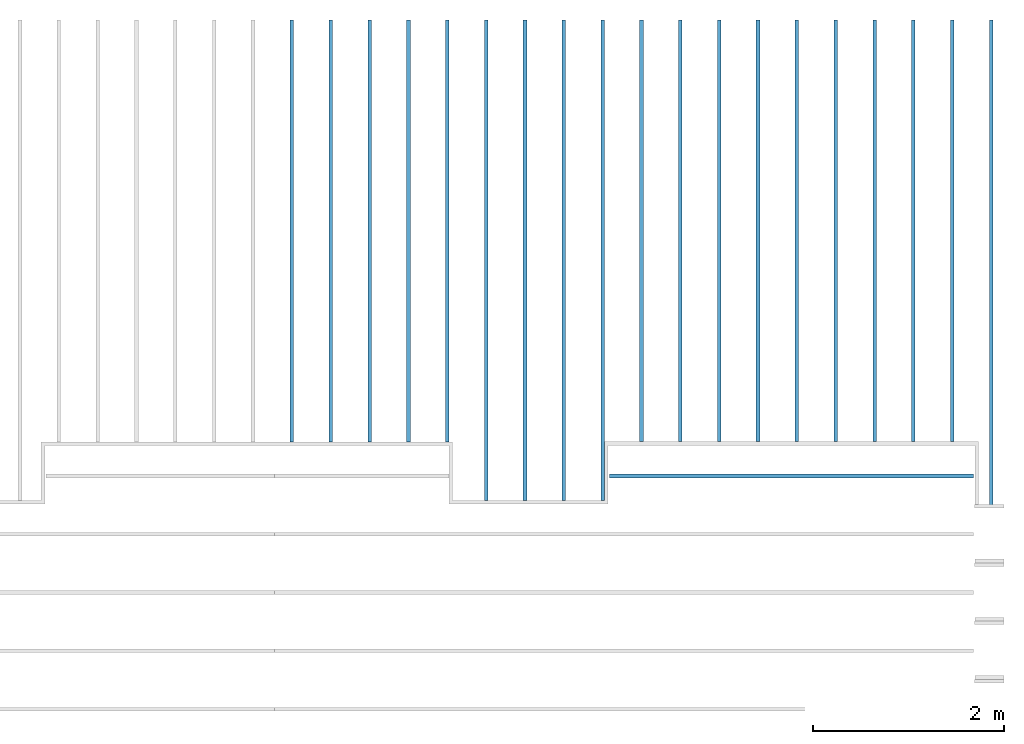
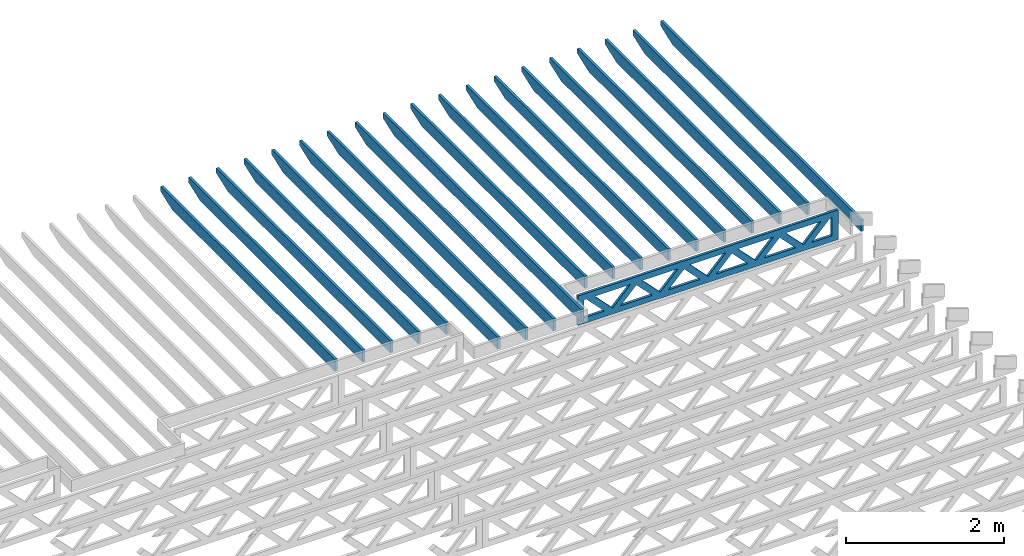
# One storey, part 13 of 18: 20 beams, 2 elements without a shape of their own.
"""IFC4 building model written with IfcOpenShell, lengths in feet."""

from ifc_helpers import new_model, entity, si_unit, converted_unit, derived_unit, direction, frame, frame_2d, origin, origin_2d_with_axis, place, context, subcontext, project, spatial, rectangle, extrude, clip, halfspace, source, transform, mapped, material, material_profile, profile_set, profile_usage, type_object, type_shapes, element, aggregate, save


model = new_model("IFC4")

# Units and contexts
model_context_1 = context("Model", 3, precision=0.0001, world=origin(), true_north=direction((6.12303176911189e-17, 1.0)))
model_context_2 = context("Model", 3, precision=0.0001, world=origin(), true_north=direction((6.12303176911189e-17, 1.0)))
body_context = subcontext(model_context_2, "Body", "Model", "MODEL_VIEW")
ifc_project = project(units=[converted_unit("LENGTHUNIT", "FOOT", entity("IfcRatioMeasure", 0.3048), si_unit("LENGTHUNIT", "METRE"), dimensions=[1, 0, 0, 0, 0, 0, 0]), converted_unit("AREAUNIT", "SQUARE FOOT", entity("IfcRatioMeasure", 0.09290304), si_unit("AREAUNIT", "SQUARE_METRE"), dimensions=[2, 0, 0, 0, 0, 0, 0]), converted_unit("VOLUMEUNIT", "CUBIC FOOT", entity("IfcRatioMeasure", 0.028316846592), si_unit("VOLUMEUNIT", "CUBIC_METRE"), dimensions=[3, 0, 0, 0, 0, 0, 0]), converted_unit("PLANEANGLEUNIT", "DEGREE", entity("IfcRatioMeasure", 0.0174532925199433), si_unit("PLANEANGLEUNIT", "RADIAN"), dimensions=[0, 0, 0, 0, 0, 0, 0]), si_unit("MASSUNIT", "GRAM", prefix="KILO"), derived_unit("MASSDENSITYUNIT", [(si_unit("MASSUNIT", "GRAM", prefix="KILO"), 1), (si_unit("LENGTHUNIT", "METRE"), -3)]), derived_unit("MOMENTOFINERTIAUNIT", [(si_unit("LENGTHUNIT", "METRE"), 4)]), si_unit("TIMEUNIT", "SECOND"), si_unit("FREQUENCYUNIT", "HERTZ"), si_unit("THERMODYNAMICTEMPERATUREUNIT", "DEGREE_CELSIUS"), derived_unit("THERMALTRANSMITTANCEUNIT", [(si_unit("MASSUNIT", "GRAM", prefix="KILO"), 1), (si_unit("THERMODYNAMICTEMPERATUREUNIT", "KELVIN"), -1), (si_unit("TIMEUNIT", "SECOND"), -3)]), derived_unit("VOLUMETRICFLOWRATEUNIT", [(si_unit("LENGTHUNIT", "METRE"), 3), (si_unit("TIMEUNIT", "SECOND"), -1)]), si_unit("ELECTRICCURRENTUNIT", "AMPERE"), si_unit("ELECTRICVOLTAGEUNIT", "VOLT"), si_unit("POWERUNIT", "WATT"), si_unit("FORCEUNIT", "NEWTON"), si_unit("ILLUMINANCEUNIT", "LUX"), si_unit("LUMINOUSFLUXUNIT", "LUMEN"), si_unit("LUMINOUSINTENSITYUNIT", "CANDELA"), derived_unit("USERDEFINED", [(si_unit("MASSUNIT", "GRAM", prefix="KILO"), -1), (si_unit("LENGTHUNIT", "METRE"), -2), (si_unit("TIMEUNIT", "SECOND"), 3), (si_unit("LUMINOUSFLUXUNIT", "LUMEN"), 1)]), derived_unit("LINEARVELOCITYUNIT", [(si_unit("LENGTHUNIT", "METRE"), 1), (si_unit("TIMEUNIT", "SECOND"), -1)]), si_unit("PRESSUREUNIT", "PASCAL"), derived_unit("USERDEFINED", [(si_unit("LENGTHUNIT", "METRE"), -2), (si_unit("MASSUNIT", "GRAM", prefix="KILO"), 1), (si_unit("TIMEUNIT", "SECOND"), -2)]), derived_unit("LINEARFORCEUNIT", [(si_unit("MASSUNIT", "GRAM", prefix="KILO"), 1), (si_unit("LENGTHUNIT", "METRE"), 1), (si_unit("TIMEUNIT", "SECOND"), -2), (si_unit("LENGTHUNIT", "METRE"), -1)]), derived_unit("PLANARFORCEUNIT", [(si_unit("MASSUNIT", "GRAM", prefix="KILO"), 1), (si_unit("LENGTHUNIT", "METRE"), 1), (si_unit("TIMEUNIT", "SECOND"), -2), (si_unit("LENGTHUNIT", "METRE"), -2)])], contexts=[model_context_1])

# Site, building, storey
site_placement = place(None, origin())
site = spatial("IfcSite", under=ifc_project, at=site_placement, CompositionType="ELEMENT")
building_placement = place(site_placement, origin())
building = spatial("IfcBuilding", under=site, at=building_placement, CompositionType="ELEMENT")
storey_placement = place(building_placement, frame((0.0, 0.0, 30.4375000000082)))
storey = spatial("IfcBuildingStorey", under=building, at=storey_placement, Name="ROOF", CompositionType="ELEMENT", Elevation=30.4375000000082)

# Assembly, beams
assembly_1_placement = place(storey_placement, origin())
assembly_1 = element("IfcElementAssembly", 1, at=assembly_1_placement, inside=storey, Name="Structural Beam System:Structural Framing System", ObjectType="Structural Beam System:Structural Framing System", AssemblyPlace="NOTDEFINED", PredefinedType="BEAM_GRID")
ifc_material_1 = material(Name="2X ROOF JOISTS - EXT. STAIN-1 - SEE LIFE SAFETY", Category="Materials")
ifc_material_profile_1 = material_profile(ifc_material_1, rectangle(XDim=0.604166666666667, YDim=0.125000000000011, at=frame_2d((0.0, 0.0), x_axis=(0.0, 1.0))))
ifc_profile_set_1 = profile_set([ifc_material_profile_1])
ifc_profile_usage_1 = profile_usage(ifc_profile_set_1, cardinal=8)
beam_type_1 = type_object("IfcBeamType", PredefinedType="BEAM", material=ifc_profile_set_1)
shared_shape_1 = source(origin(), body_context, "Body", "Clipping", [
    clip(extrude(rectangle(XDim=0.604166666666667, YDim=0.125000000000011, at=frame_2d((0.0, 0.0), x_axis=(0.0, 1.0))), frame((-8.24296473987818, 0.0, 0.0), z_axis=(1.0, 0.0, 0.0), x_axis=(0.0, 1.0, 0.0)), (0.0, 0.0, 1.0), 16.4859294797564), halfspace(frame((-7.26989982048795, -0.0625000000000026, -0.30208333333334), z_axis=(-0.34202014332567, 0.0, -0.939692620785908), x_axis=(0.0, 1.0, 0.0)), False)),
])
type_shapes(beam_type_1, [shared_shape_1])
beam_1_placement = place(assembly_1_placement, frame((-154.467327152128, 965.271566289195, 1.07291666665829), z_axis=(0.0, 0.0, 1.0), x_axis=(0.0, -1.0, 0.0)))
beam_1 = element("IfcBeam", 2, at=beam_1_placement, type_object=beam_type_1, material=ifc_profile_usage_1, PredefinedType="BEAM", context=body_context, shape_type="MappedRepresentation", body=[
    mapped(shared_shape_1, transform((0.0, 0.0, 0.0), scale=1.0)),
])
ifc_profile_usage_2 = profile_usage(ifc_profile_set_1, cardinal=8)
beam_2_placement = place(assembly_1_placement, frame((-153.133993818795, 965.271566289195, 1.07291666665829), z_axis=(0.0, 0.0, 1.0), x_axis=(0.0, -1.0, 0.0)))
beam_2 = element("IfcBeam", 3, at=beam_2_placement, type_object=beam_type_1, material=ifc_profile_usage_2, PredefinedType="BEAM", context=body_context, shape_type="MappedRepresentation", body=[
    mapped(shared_shape_1, transform((0.0, 0.0, 0.0), scale=1.0)),
])
ifc_profile_usage_3 = profile_usage(ifc_profile_set_1, cardinal=8)
beam_3_placement = place(assembly_1_placement, frame((-155.800660485462, 965.271566289195, 1.07291666665829), z_axis=(0.0, 0.0, 1.0), x_axis=(0.0, -1.0, 0.0)))
beam_3 = element("IfcBeam", 4, at=beam_3_placement, type_object=beam_type_1, material=ifc_profile_usage_3, PredefinedType="BEAM", context=body_context, shape_type="MappedRepresentation", body=[
    mapped(shared_shape_1, transform((0.0, 0.0, 0.0), scale=1.0)),
])
ifc_profile_usage_4 = profile_usage(ifc_profile_set_1, cardinal=8)
beam_4_placement = place(assembly_1_placement, frame((-157.133993818795, 965.271566289195, 1.07291666665829), z_axis=(0.0, 0.0, 1.0), x_axis=(0.0, -1.0, 0.0)))
beam_4 = element("IfcBeam", 5, at=beam_4_placement, type_object=beam_type_1, material=ifc_profile_usage_4, PredefinedType="BEAM", context=body_context, shape_type="MappedRepresentation", body=[
    mapped(shared_shape_1, transform((0.0, 0.0, 0.0), scale=1.0)),
])
ifc_profile_usage_5 = profile_usage(ifc_profile_set_1, cardinal=8)
beam_type_2 = type_object("IfcBeamType", PredefinedType="BEAM", material=ifc_profile_set_1)
shared_shape_2 = source(origin(), body_context, "Body", "Clipping", [
    clip(extrude(rectangle(XDim=0.604166666666667, YDim=0.125000000000011, at=frame_2d((0.0, 0.0), x_axis=(0.0, 1.0))), frame((-7.24296378214677, 0.0, 0.0), z_axis=(1.0, 0.0, 0.0), x_axis=(0.0, 1.0, 0.0)), (0.0, 0.0, 1.0), 14.4859275642935), halfspace(frame((-6.26989886275655, -0.0625000000000026, -0.30208333333334), z_axis=(-0.34202014332567, 0.0, -0.939692620785908), x_axis=(0.0, 1.0, 0.0)), False)),
])
type_shapes(beam_type_2, [shared_shape_2])
beam_5_placement = place(assembly_1_placement, frame((-161.133993818795, 966.271567246926, 1.07291666665829), z_axis=(0.0, 0.0, 1.0), x_axis=(0.0, -1.0, 0.0)))
beam_5 = element("IfcBeam", 6, at=beam_5_placement, type_object=beam_type_2, material=ifc_profile_usage_5, PredefinedType="BEAM", context=body_context, shape_type="MappedRepresentation", body=[
    mapped(shared_shape_2, transform((0.0, 0.0, 0.0), scale=1.0)),
])
ifc_profile_usage_6 = profile_usage(ifc_profile_set_1, cardinal=8)
beam_type_3 = type_object("IfcBeamType", PredefinedType="BEAM", material=ifc_profile_set_1)
shared_shape_3 = source(origin(), body_context, "Body", "Clipping", [
    clip(extrude(rectangle(XDim=0.604166666666667, YDim=0.125000000000011, at=frame_2d((0.0, 0.0), x_axis=(0.0, 1.0))), frame((-7.24296361464559, 0.0, 0.0), z_axis=(1.0, 0.0, 0.0), x_axis=(0.0, 1.0, 0.0)), (0.0, 0.0, 1.0), 14.4859272292912), halfspace(frame((-6.26989869525536, -0.0625000000000026, -0.30208333333334), z_axis=(-0.34202014332567, 0.0, -0.939692620785908), x_axis=(0.0, 1.0, 0.0)), False)),
])
type_shapes(beam_type_3, [shared_shape_3])
beam_6_placement = place(assembly_1_placement, frame((-159.800660485462, 966.271567414428, 1.07291666665829), z_axis=(0.0, 0.0, 1.0), x_axis=(0.0, -1.0, 0.0)))
beam_6 = element("IfcBeam", 7, at=beam_6_placement, type_object=beam_type_3, material=ifc_profile_usage_6, PredefinedType="BEAM", context=body_context, shape_type="MappedRepresentation", body=[
    mapped(shared_shape_3, transform((0.0, 0.0, 0.0), scale=1.0)),
])
ifc_profile_usage_7 = profile_usage(ifc_profile_set_1, cardinal=8)
beam_type_4 = type_object("IfcBeamType", PredefinedType="BEAM", material=ifc_profile_set_1)
shared_shape_4 = source(origin(), body_context, "Body", "Clipping", [
    clip(extrude(rectangle(XDim=0.604166666666667, YDim=0.125000000000011, at=frame_2d((0.0, 0.0), x_axis=(0.0, 1.0))), frame((-7.24296411714914, 0.0, 0.0), z_axis=(1.0, 0.0, 0.0), x_axis=(0.0, 1.0, 0.0)), (0.0, 0.0, 1.0), 14.4859282342983), halfspace(frame((-6.26989919775892, -0.0625000000000026, -0.30208333333334), z_axis=(-0.34202014332567, 0.0, -0.939692620785908), x_axis=(0.0, 1.0, 0.0)), False)),
])
type_shapes(beam_type_4, [shared_shape_4])
beam_7_placement = place(assembly_1_placement, frame((-163.800660485462, 966.271566911924, 1.07291666665829), z_axis=(0.0, 0.0, 1.0), x_axis=(0.0, -1.0, 0.0)))
beam_7 = element("IfcBeam", 8, at=beam_7_placement, type_object=beam_type_4, material=ifc_profile_usage_7, PredefinedType="BEAM", context=body_context, shape_type="MappedRepresentation", body=[
    mapped(shared_shape_4, transform((0.0, 0.0, 0.0), scale=1.0)),
])
ifc_profile_usage_8 = profile_usage(ifc_profile_set_1, cardinal=8)
beam_type_5 = type_object("IfcBeamType", PredefinedType="BEAM", material=ifc_profile_set_1)
shared_shape_5 = source(origin(), body_context, "Body", "Clipping", [
    clip(extrude(rectangle(XDim=0.604166666666667, YDim=0.125000000000011, at=frame_2d((0.0, 0.0), x_axis=(0.0, 1.0))), frame((-7.24296394964796, 0.0, 0.0), z_axis=(1.0, 0.0, 0.0), x_axis=(0.0, 1.0, 0.0)), (0.0, 0.0, 1.0), 14.4859278992959), halfspace(frame((-6.26989903025773, -0.0625000000000026, -0.30208333333334), z_axis=(-0.34202014332567, 0.0, -0.939692620785908), x_axis=(0.0, 1.0, 0.0)), False)),
])
type_shapes(beam_type_5, [shared_shape_5])
beam_8_placement = place(assembly_1_placement, frame((-162.467327152128, 966.271567079425, 1.07291666665829), z_axis=(0.0, 0.0, 1.0), x_axis=(0.0, -1.0, 0.0)))
beam_8 = element("IfcBeam", 9, at=beam_8_placement, type_object=beam_type_5, material=ifc_profile_usage_8, PredefinedType="BEAM", context=body_context, shape_type="MappedRepresentation", body=[
    mapped(shared_shape_5, transform((0.0, 0.0, 0.0), scale=1.0)),
])
ifc_profile_usage_9 = profile_usage(ifc_profile_set_1, cardinal=8)
beam_type_6 = type_object("IfcBeamType", PredefinedType="BEAM", material=ifc_profile_set_1)
shared_shape_6 = source(origin(), body_context, "Body", "Clipping", [
    clip(extrude(rectangle(XDim=0.604166666666667, YDim=0.125000000000011, at=frame_2d((0.0, -1.11022302462516e-16), x_axis=(0.0, 1.0))), frame((-7.23775791197056, 0.0, 0.0), z_axis=(1.0, 0.0, 0.0), x_axis=(0.0, 1.0, 0.0)), (0.0, 0.0, 1.0), 14.4755158239411), halfspace(frame((-6.26469299258034, -0.0625000000000026, -0.30208333333334), z_axis=(-0.34202014332567, 0.0, -0.939692620785908), x_axis=(0.0, 1.0, 0.0)), False)),
])
type_shapes(beam_type_6, [shared_shape_6])
beam_9_placement = place(assembly_1_placement, frame((-150.467327152128, 966.276773117103, 1.0729166666581), z_axis=(0.0, 0.0, 1.0), x_axis=(0.0, -1.0, 0.0)))
beam_9 = element("IfcBeam", 10, at=beam_9_placement, type_object=beam_type_6, material=ifc_profile_usage_9, PredefinedType="BEAM", context=body_context, shape_type="MappedRepresentation", body=[
    mapped(shared_shape_6, transform((0.0, 0.0, 0.0), scale=1.0)),
])
ifc_profile_usage_10 = profile_usage(ifc_profile_set_1, cardinal=8)
beam_type_7 = type_object("IfcBeamType", PredefinedType="BEAM", material=ifc_profile_set_1)
shared_shape_7 = source(origin(), body_context, "Body", "Clipping", [
    clip(extrude(rectangle(XDim=0.604166666666667, YDim=0.125000000000011, at=frame_2d((0.0, 0.0), x_axis=(0.0, 1.0))), frame((-7.23775724196577, 0.0, 0.0), z_axis=(1.0, 0.0, 0.0), x_axis=(0.0, 1.0, 0.0)), (0.0, 0.0, 1.0), 14.4755144839315), halfspace(frame((-6.26469232257554, -0.0625000000000026, -0.30208333333334), z_axis=(-0.34202014332567, 0.0, -0.939692620785908), x_axis=(0.0, 1.0, 0.0)), False)),
])
type_shapes(beam_type_7, [shared_shape_7])
beam_10_placement = place(assembly_1_placement, frame((-145.133993818795, 966.276773787107, 1.07291666665808), z_axis=(0.0, 0.0, 1.0), x_axis=(0.0, -1.0, 0.0)))
beam_10 = element("IfcBeam", 11, at=beam_10_placement, type_object=beam_type_7, material=ifc_profile_usage_10, PredefinedType="BEAM", context=body_context, shape_type="MappedRepresentation", body=[
    mapped(shared_shape_7, transform((0.0, 0.0, 0.0), scale=1.0)),
])
ifc_profile_usage_11 = profile_usage(ifc_profile_set_1, cardinal=8)
beam_type_8 = type_object("IfcBeamType", PredefinedType="BEAM", material=ifc_profile_set_1)
shared_shape_8 = source(origin(), body_context, "Body", "Clipping", [
    clip(extrude(rectangle(XDim=0.604166666666667, YDim=0.125000000000011, at=frame_2d((0.0, -1.11022302462516e-16), x_axis=(0.0, 1.0))), frame((-7.23775707446458, 0.0, 0.0), z_axis=(1.0, 0.0, 0.0), x_axis=(0.0, 1.0, 0.0)), (0.0, 0.0, 1.0), 14.4755141489292), halfspace(frame((-6.26469215507436, -0.0625000000000026, -0.30208333333334), z_axis=(-0.34202014332567, 0.0, -0.939692620785908), x_axis=(0.0, 1.0, 0.0)), False)),
])
type_shapes(beam_type_8, [shared_shape_8])
beam_11_placement = place(assembly_1_placement, frame((-143.800660485462, 966.276773954609, 1.07291666665808), z_axis=(0.0, 0.0, 1.0), x_axis=(0.0, -1.0, 0.0)))
beam_11 = element("IfcBeam", 12, at=beam_11_placement, type_object=beam_type_8, material=ifc_profile_usage_11, PredefinedType="BEAM", context=body_context, shape_type="MappedRepresentation", body=[
    mapped(shared_shape_8, transform((0.0, 0.0, 0.0), scale=1.0)),
])
ifc_profile_usage_12 = profile_usage(ifc_profile_set_1, cardinal=8)
beam_type_9 = type_object("IfcBeamType", PredefinedType="BEAM", material=ifc_profile_set_1)
shared_shape_9 = source(origin(), body_context, "Body", "Clipping", [
    clip(extrude(rectangle(XDim=0.604166666666667, YDim=0.125000000000011, at=frame_2d((0.0, 0.0), x_axis=(0.0, 1.0))), frame((-7.2377569069634, 0.0, 0.0), z_axis=(1.0, 0.0, 0.0), x_axis=(0.0, 1.0, 0.0)), (0.0, 0.0, 1.0), 14.4755138139268), halfspace(frame((-6.26469198757317, -0.0625000000000026, -0.30208333333334), z_axis=(-0.34202014332567, 0.0, -0.939692620785908), x_axis=(0.0, 1.0, 0.0)), False)),
])
type_shapes(beam_type_9, [shared_shape_9])
beam_12_placement = place(assembly_1_placement, frame((-142.467327152128, 966.27677412211, 1.07291666665807), z_axis=(0.0, 0.0, 1.0), x_axis=(0.0, -1.0, 0.0)))
beam_12 = element("IfcBeam", 13, at=beam_12_placement, type_object=beam_type_9, material=ifc_profile_usage_12, PredefinedType="BEAM", context=body_context, shape_type="MappedRepresentation", body=[
    mapped(shared_shape_9, transform((0.0, 0.0, 0.0), scale=1.0)),
])
ifc_profile_usage_13 = profile_usage(ifc_profile_set_1, cardinal=8)
beam_type_10 = type_object("IfcBeamType", PredefinedType="BEAM", material=ifc_profile_set_1)
shared_shape_10 = source(origin(), body_context, "Body", "Clipping", [
    clip(extrude(rectangle(XDim=0.604166666666667, YDim=0.125000000000011, at=frame_2d((0.0, 0.0), x_axis=(0.0, 1.0))), frame((-7.23775673946221, 0.0, 0.0), z_axis=(1.0, 0.0, 0.0), x_axis=(0.0, 1.0, 0.0)), (0.0, 0.0, 1.0), 14.4755134789244), halfspace(frame((-6.26469182007199, -0.0625000000000026, -0.30208333333334), z_axis=(-0.34202014332567, 0.0, -0.939692620785908), x_axis=(0.0, 1.0, 0.0)), False)),
])
type_shapes(beam_type_10, [shared_shape_10])
beam_13_placement = place(assembly_1_placement, frame((-141.133993818795, 966.276774289611, 1.07291666665807), z_axis=(0.0, 0.0, 1.0), x_axis=(0.0, -1.0, 0.0)))
beam_13 = element("IfcBeam", 14, at=beam_13_placement, type_object=beam_type_10, material=ifc_profile_usage_13, PredefinedType="BEAM", context=body_context, shape_type="MappedRepresentation", body=[
    mapped(shared_shape_10, transform((0.0, 0.0, 0.0), scale=1.0)),
])
ifc_profile_usage_14 = profile_usage(ifc_profile_set_1, cardinal=8)
beam_type_11 = type_object("IfcBeamType", PredefinedType="BEAM", material=ifc_profile_set_1)
shared_shape_11 = source(origin(), body_context, "Body", "Clipping", [
    clip(extrude(rectangle(XDim=0.604166666666667, YDim=0.125000000000011, at=frame_2d((0.0, 0.0), x_axis=(0.0, 1.0))), frame((-8.32629807321177, 0.0, 0.0), z_axis=(1.0, 0.0, 0.0), x_axis=(0.0, 1.0, 0.0)), (0.0, 0.0, 1.0), 16.6525961464235), halfspace(frame((-7.35323315382155, -0.0625000000000026, -0.30208333333334), z_axis=(-0.34202014332567, 0.0, -0.939692620785908), x_axis=(0.0, 1.0, 0.0)), False)),
])
type_shapes(beam_type_11, [shared_shape_11])
beam_14_placement = place(assembly_1_placement, frame((-139.800660485462, 965.188232955862, 1.07291666665828), z_axis=(0.0, 0.0, 1.0), x_axis=(0.0, -1.0, 0.0)))
beam_14 = element("IfcBeam", 15, at=beam_14_placement, type_object=beam_type_11, material=ifc_profile_usage_14, PredefinedType="BEAM", context=body_context, shape_type="MappedRepresentation", body=[
    mapped(shared_shape_11, transform((0.0, 0.0, 0.0), scale=1.0)),
])
ifc_profile_usage_15 = profile_usage(ifc_profile_set_1, cardinal=8)
beam_type_12 = type_object("IfcBeamType", PredefinedType="BEAM", material=ifc_profile_set_1)
shared_shape_12 = source(origin(), body_context, "Body", "Clipping", [
    clip(extrude(rectangle(XDim=0.604166666666667, YDim=0.125000000000011, at=frame_2d((0.0, 0.0), x_axis=(0.0, 1.0))), frame((-7.23775740946695, 0.0, 0.0), z_axis=(1.0, 0.0, 0.0), x_axis=(0.0, 1.0, 0.0)), (0.0, 0.0, 1.0), 14.4755148189339), halfspace(frame((-6.26469249007672, -0.0625000000000026, -0.30208333333334), z_axis=(-0.34202014332567, 0.0, -0.939692620785908), x_axis=(0.0, 1.0, 0.0)), False)),
])
type_shapes(beam_type_12, [shared_shape_12])
beam_15_placement = place(assembly_1_placement, frame((-146.467327152128, 966.276773619606, 1.07291666665808), z_axis=(0.0, 0.0, 1.0), x_axis=(0.0, -1.0, 0.0)))
beam_15 = element("IfcBeam", 16, at=beam_15_placement, type_object=beam_type_12, material=ifc_profile_usage_15, PredefinedType="BEAM", context=body_context, shape_type="MappedRepresentation", body=[
    mapped(shared_shape_12, transform((0.0, 0.0, 0.0), scale=1.0)),
])
ifc_profile_usage_16 = profile_usage(ifc_profile_set_1, cardinal=8)
beam_type_13 = type_object("IfcBeamType", PredefinedType="BEAM", material=ifc_profile_set_1)
shared_shape_13 = source(origin(), body_context, "Body", "Clipping", [
    clip(extrude(rectangle(XDim=0.604166666666667, YDim=0.125000000000011, at=frame_2d((0.0, 0.0), x_axis=(0.0, 1.0))), frame((-7.23775757696819, 0.0, 0.0), z_axis=(1.0, 0.0, 0.0), x_axis=(0.0, 1.0, 0.0)), (0.0, 0.0, 1.0), 14.4755151539364), halfspace(frame((-6.26469265757797, -0.0625000000000026, -0.30208333333334), z_axis=(-0.34202014332567, 0.0, -0.939692620785908), x_axis=(0.0, 1.0, 0.0)), False)),
])
type_shapes(beam_type_13, [shared_shape_13])
beam_16_placement = place(assembly_1_placement, frame((-147.800660485462, 966.276773452105, 1.07291666665809), z_axis=(0.0, 0.0, 1.0), x_axis=(0.0, -1.0, 0.0)))
beam_16 = element("IfcBeam", 17, at=beam_16_placement, type_object=beam_type_13, material=ifc_profile_usage_16, PredefinedType="BEAM", context=body_context, shape_type="MappedRepresentation", body=[
    mapped(shared_shape_13, transform((0.0, 0.0, 0.0), scale=1.0)),
])
ifc_profile_usage_17 = profile_usage(ifc_profile_set_1, cardinal=8)
beam_type_14 = type_object("IfcBeamType", PredefinedType="BEAM", material=ifc_profile_set_1)
shared_shape_14 = source(origin(), body_context, "Body", "Clipping", [
    clip(extrude(rectangle(XDim=0.604166666666667, YDim=0.125000000000011, at=frame_2d((0.0, 0.0), x_axis=(0.0, 1.0))), frame((-7.23775774446938, 0.0, 0.0), z_axis=(1.0, 0.0, 0.0), x_axis=(0.0, 1.0, 0.0)), (0.0, 0.0, 1.0), 14.4755154889388), halfspace(frame((-6.26469282507915, -0.0625000000000026, -0.30208333333334), z_axis=(-0.34202014332567, 0.0, -0.939692620785908), x_axis=(0.0, 1.0, 0.0)), False)),
])
type_shapes(beam_type_14, [shared_shape_14])
beam_17_placement = place(assembly_1_placement, frame((-149.133993818795, 966.276773284604, 1.07291666665809), z_axis=(0.0, 0.0, 1.0), x_axis=(0.0, -1.0, 0.0)))
beam_17 = element("IfcBeam", 18, at=beam_17_placement, type_object=beam_type_14, material=ifc_profile_usage_17, PredefinedType="BEAM", context=body_context, shape_type="MappedRepresentation", body=[
    mapped(shared_shape_14, transform((0.0, 0.0, 0.0), scale=1.0)),
])
ifc_profile_usage_18 = profile_usage(ifc_profile_set_1, cardinal=8)
beam_type_15 = type_object("IfcBeamType", PredefinedType="BEAM", material=ifc_profile_set_1)
shared_shape_15 = source(origin(), body_context, "Body", "Clipping", [
    clip(extrude(rectangle(XDim=0.604166666666667, YDim=0.125000000000011, at=frame_2d((0.0, 0.0), x_axis=(0.0, 1.0))), frame((-7.23775807947175, 0.0, 0.0), z_axis=(1.0, 0.0, 0.0), x_axis=(0.0, 1.0, 0.0)), (0.0, 0.0, 1.0), 14.4755161589435), halfspace(frame((-6.26469316008152, -0.0625000000000026, -0.30208333333334), z_axis=(-0.34202014332567, 0.0, -0.939692620785908), x_axis=(0.0, 1.0, 0.0)), False)),
])
type_shapes(beam_type_15, [shared_shape_15])
beam_18_placement = place(assembly_1_placement, frame((-151.800660485462, 966.276772949602, 1.0729166666581), z_axis=(0.0, 0.0, 1.0), x_axis=(0.0, -1.0, 0.0)))
beam_18 = element("IfcBeam", 19, at=beam_18_placement, type_object=beam_type_15, material=ifc_profile_usage_18, PredefinedType="BEAM", context=body_context, shape_type="MappedRepresentation", body=[
    mapped(shared_shape_15, transform((0.0, 0.0, 0.0), scale=1.0)),
])
ifc_profile_usage_19 = profile_usage(ifc_profile_set_1, cardinal=8)
beam_type_16 = type_object("IfcBeamType", PredefinedType="BEAM", material=ifc_profile_set_1)
shared_shape_16 = source(origin(), body_context, "Body", "Clipping", [
    clip(extrude(rectangle(XDim=0.604166666666667, YDim=0.125000000000011, at=frame_2d((0.0, 0.0), x_axis=(0.0, 1.0))), frame((-7.2429634471444, 0.0, 0.0), z_axis=(1.0, 0.0, 0.0), x_axis=(0.0, 1.0, 0.0)), (0.0, 0.0, 1.0), 14.4859268942888), halfspace(frame((-6.26989852775418, -0.0625000000000026, -0.30208333333334), z_axis=(-0.34202014332567, 0.0, -0.939692620785908), x_axis=(0.0, 1.0, 0.0)), False)),
])
type_shapes(beam_type_16, [shared_shape_16])
beam_19_placement = place(assembly_1_placement, frame((-158.467327152128, 966.271567581929, 1.07291666665829), z_axis=(0.0, 0.0, 1.0), x_axis=(0.0, -1.0, 0.0)))
beam_19 = element("IfcBeam", 20, at=beam_19_placement, type_object=beam_type_16, material=ifc_profile_usage_19, PredefinedType="BEAM", context=body_context, shape_type="MappedRepresentation", body=[
    mapped(shared_shape_16, transform((0.0, 0.0, 0.0), scale=1.0)),
])
aggregate(assembly_1, [beam_7, beam_8, beam_5, beam_1, beam_9, beam_10, beam_11, beam_12, beam_13, beam_14, beam_15, beam_16, beam_17, beam_18, beam_2, beam_3, beam_4, beam_19, beam_6])

# Assembly, beam
assembly_2_placement = place(storey_placement, origin())
assembly_2 = element("IfcElementAssembly", 21, at=assembly_2_placement, inside=storey, Name="Structural Beam System:Structural Framing System", ObjectType="Structural Beam System:Structural Framing System", AssemblyPlace="NOTDEFINED", PredefinedType="BEAM_GRID")
ifc_material_2 = material(Name="WOOD TRUSS", Category="Materials")
ifc_material_profile_2 = material_profile(ifc_material_2, rectangle(XDim=1.73473973950632, YDim=0.125, at=origin_2d_with_axis()))
ifc_material_profile_3 = material_profile(ifc_material_2, rectangle(XDim=1.73473973950633, YDim=0.125, at=frame_2d((-1.11022302462516e-16, 0.0), x_axis=(1.0, 0.0))))
ifc_material_profile_4 = material_profile(ifc_material_2, rectangle(XDim=1.73473973950632, YDim=0.125, at=origin_2d_with_axis()))
ifc_material_profile_5 = material_profile(ifc_material_2, rectangle(XDim=1.73473973950633, YDim=0.125, at=origin_2d_with_axis()))
ifc_material_profile_6 = material_profile(ifc_material_2, rectangle(XDim=1.73473973950632, YDim=0.125, at=frame_2d((-5.55111512312578e-17, 0.0), x_axis=(1.0, 0.0))))
ifc_material_profile_7 = material_profile(ifc_material_2, rectangle(XDim=1.73473973950633, YDim=0.125, at=frame_2d((-2.77555756156289e-16, 0.0), x_axis=(1.0, 0.0))))
ifc_material_profile_8 = material_profile(ifc_material_2, rectangle(XDim=1.73473973950632, YDim=0.125, at=frame_2d((-4.9960036108132e-16, 0.0), x_axis=(1.0, 0.0))))
ifc_material_profile_9 = material_profile(ifc_material_2, rectangle(XDim=1.73473973950633, YDim=0.125, at=frame_2d((4.44089209850063e-16, 0.0), x_axis=(1.0, 0.0))))
ifc_material_profile_10 = material_profile(ifc_material_2, rectangle(XDim=1.73473973950632, YDim=0.125, at=origin_2d_with_axis()))
ifc_material_profile_11 = material_profile(ifc_material_2, rectangle(XDim=1.73473973950633, YDim=0.125, at=frame_2d((-4.9960036108132e-16, 0.0), x_axis=(1.0, 0.0))))
ifc_material_profile_12 = material_profile(ifc_material_2, rectangle(XDim=0.291666666666664, YDim=0.125, at=frame_2d((-2.77555756156289e-17, 0.0), x_axis=(1.0, 0.0))))
ifc_material_profile_13 = material_profile(ifc_material_2, rectangle(XDim=0.291666666666628, YDim=0.124999999999995, at=frame_2d((-5.55111512312578e-17, 0.0), x_axis=(1.0, 0.0))))
ifc_material_profile_14 = material_profile(ifc_material_2, rectangle(XDim=0.916666666666666, YDim=0.125000000000003, at=frame_2d((-2.77555756156289e-17, 0.0), x_axis=(1.0, 0.0))))
ifc_material_profile_15 = material_profile(ifc_material_2, rectangle(XDim=0.916666666666651, YDim=0.125, at=frame_2d((-2.77555756156289e-17, 0.0), x_axis=(1.0, 0.0))))
ifc_profile_set_2 = profile_set([ifc_material_profile_2, ifc_material_profile_3, ifc_material_profile_4, ifc_material_profile_5, ifc_material_profile_6, ifc_material_profile_7, ifc_material_profile_8, ifc_material_profile_9, ifc_material_profile_10, ifc_material_profile_11, ifc_material_profile_12, ifc_material_profile_13, ifc_material_profile_14, ifc_material_profile_15])
ifc_profile_usage_20 = profile_usage(ifc_profile_set_2, cardinal=8)
beam_type_17 = type_object("IfcBeamType", PredefinedType="BEAM", material=ifc_profile_set_2)
shared_shape_17 = source(origin(), body_context, "Body", "SweptSolid", [
    extrude(rectangle(XDim=1.73473973950632, YDim=0.125, at=origin_2d_with_axis()), frame((2.81172855039779, 0.0, 0.101118361020562), z_axis=(0.720569184836762, 0.0, -0.693383046997606), x_axis=(0.693383046997606, 0.0, 0.720569184836762)), (0.0, 0.0, 1.0), 0.291666666666667),
    extrude(rectangle(XDim=1.73473973950633, YDim=0.125, at=frame_2d((-1.11022302462516e-16, 0.0), x_axis=(1.0, 0.0))), frame((1.56144267672452, 0.0, -0.101118361020407), z_axis=(0.720569184836758, 0.0, 0.69338304699761), x_axis=(0.69338304699761, 0.0, -0.720569184836758)), (0.0, 0.0, 1.0), 0.291666666666666),
    extrude(rectangle(XDim=1.73473973950632, YDim=0.125, at=origin_2d_with_axis()), frame((0.520059930714936, 0.0, 0.101118361020562), z_axis=(0.720569184836762, 0.0, -0.693383046997606), x_axis=(0.693383046997606, 0.0, 0.720569184836762)), (0.0, 0.0, 1.0), 0.291666666666667),
    extrude(rectangle(XDim=1.73473973950633, YDim=0.125, at=origin_2d_with_axis()), frame((-0.730225942958334, 0.0, -0.101118361020407), z_axis=(0.720569184836758, 0.0, 0.69338304699761), x_axis=(0.69338304699761, 0.0, -0.720569184836758)), (0.0, 0.0, 1.0), 0.291666666666666),
    extrude(rectangle(XDim=1.73473973950632, YDim=0.125, at=frame_2d((-5.55111512312578e-17, 0.0), x_axis=(1.0, 0.0))), frame((-1.77160868896792, 0.0, 0.101118361020562), z_axis=(0.720569184836762, 0.0, -0.693383046997606), x_axis=(0.693383046997606, 0.0, 0.720569184836762)), (0.0, 0.0, 1.0), 0.291666666666667),
    extrude(rectangle(XDim=1.73473973950633, YDim=0.125, at=frame_2d((-2.77555756156289e-16, 0.0), x_axis=(1.0, 0.0))), frame((-3.02189456264119, 0.0, -0.101118361020407), z_axis=(0.720569184836758, 0.0, 0.69338304699761), x_axis=(0.69338304699761, 0.0, -0.720569184836758)), (0.0, 0.0, 1.0), 0.291666666666666),
    extrude(rectangle(XDim=1.73473973950632, YDim=0.125, at=frame_2d((-4.9960036108132e-16, 0.0), x_axis=(1.0, 0.0))), frame((5.10339717008065, 0.0, 0.101118361020511), z_axis=(0.720569184836761, 0.0, -0.693383046997607), x_axis=(0.693383046997607, 0.0, 0.720569184836761)), (0.0, 0.0, 1.0), 0.291666666666668),
    extrude(rectangle(XDim=1.73473973950633, YDim=0.125, at=frame_2d((4.44089209850063e-16, 0.0), x_axis=(1.0, 0.0))), frame((3.85311129640737, 0.0, -0.101118361020458), z_axis=(0.720569184836758, 0.0, 0.69338304699761), x_axis=(0.69338304699761, 0.0, -0.720569184836758)), (0.0, 0.0, 1.0), 0.291666666666666),
    extrude(rectangle(XDim=1.73473973950632, YDim=0.125, at=origin_2d_with_axis()), frame((-4.06327730865077, 0.0, 0.101118361020557), z_axis=(0.720569184836762, 0.0, -0.693383046997606), x_axis=(0.693383046997606, 0.0, 0.720569184836762)), (0.0, 0.0, 1.0), 0.291666666666668),
    extrude(rectangle(XDim=1.73473973950633, YDim=0.125, at=frame_2d((-4.9960036108132e-16, 0.0), x_axis=(1.0, 0.0))), frame((-5.31356318232404, 0.0, -0.101118361020412), z_axis=(0.720569184836758, 0.0, 0.69338304699761), x_axis=(0.69338304699761, 0.0, -0.720569184836758)), (0.0, 0.0, 1.0), 0.291666666666667),
    extrude(rectangle(XDim=0.291666666666664, YDim=0.125, at=frame_2d((-2.77555756156289e-17, 0.0), x_axis=(1.0, 0.0))), frame((-6.25000390603229, 0.0, 0.604166666666611), z_axis=(1.0, 0.0, 0.0), x_axis=(0.0, 0.0, -1.0)), (0.0, 0.0, 1.0), 12.5000078120646),
    extrude(rectangle(XDim=0.291666666666628, YDim=0.124999999999995, at=frame_2d((-5.55111512312578e-17, 0.0), x_axis=(1.0, 0.0))), frame((-6.25000390603208, 0.0, -0.604166666666693), z_axis=(1.0, 0.0, 0.0), x_axis=(0.0, 0.0, -1.0)), (0.0, 0.0, 1.0), 12.5000078120644),
    extrude(rectangle(XDim=0.916666666666666, YDim=0.125000000000003, at=frame_2d((-2.77555756156289e-17, 0.0), x_axis=(1.0, 0.0))), frame((5.9583372393656, 0.0, 0.0), z_axis=(1.0, 0.0, 0.0), x_axis=(0.0, 0.0, -1.0)), (0.0, 0.0, 1.0), 0.291666666666687),
    extrude(rectangle(XDim=0.916666666666651, YDim=0.125, at=frame_2d((-2.77555756156289e-17, 0.0), x_axis=(1.0, 0.0))), frame((-6.25000390603229, 0.0, 0.0), z_axis=(1.0, 0.0, 0.0), x_axis=(0.0, 0.0, -1.0)), (0.0, 0.0, 1.0), 0.291666666666687),
])
type_shapes(beam_type_17, [shared_shape_17])
beam_20_placement = place(assembly_2_placement, frame((-146.654823274369, 957.861934882651, 0.749999999991619), z_axis=(0.0, 0.0, 1.0), x_axis=(-1.0, 0.0, 0.0)))
beam_20 = element("IfcBeam", 22, at=beam_20_placement, type_object=beam_type_17, material=ifc_profile_usage_20, PredefinedType="BEAM", context=body_context, shape_type="MappedRepresentation", body=[
    mapped(shared_shape_17, transform((0.0, 0.0, 0.0), scale=1.0)),
])
aggregate(assembly_2, [beam_20])

save(model, "model.ifc")
